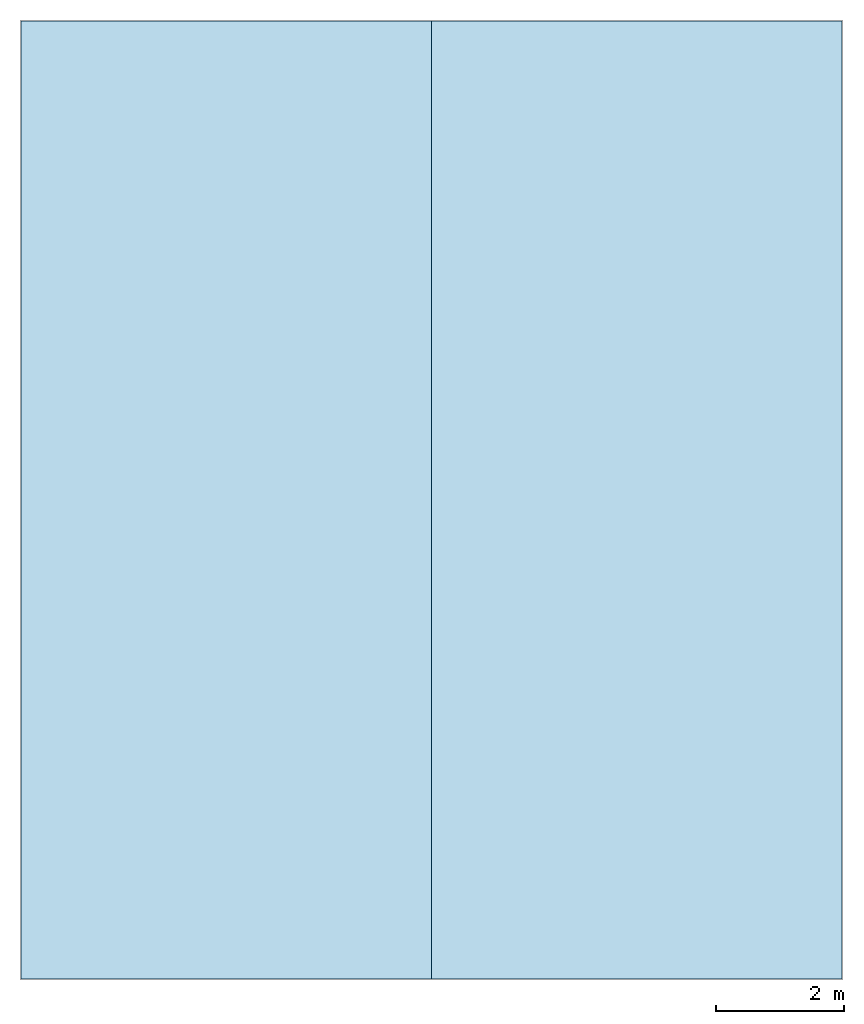
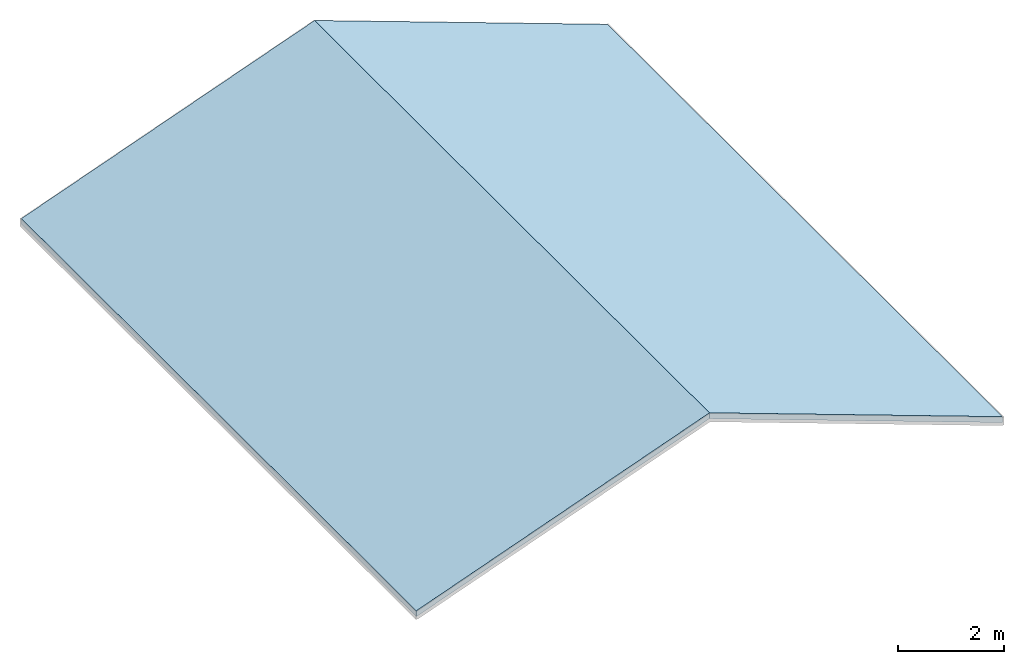
# One storey, part 1 of 2: 2 slabs, 1 element without a shape of its own.
"""IFC2X3 building model written with IfcOpenShell, lengths in feet."""

from ifc_helpers import new_model, entity, si_unit, converted_unit, derived_unit, direction, frame, frame_2d, origin, origin_2d_with_axis, place, context, subcontext, project, spatial, rectangle, extrude, material, layer, layer_set, type_object, element, aggregate, save


model = new_model("IFC2X3")

# Units and contexts
model_context = context("Model", 3, precision=0.0001, world=origin(), true_north=direction((6.123031769111886e-17, 1.0)))
body_context = subcontext(model_context, "Body", "Model", "MODEL_VIEW")
ifc_project = project(units=[converted_unit("LENGTHUNIT", "FOOT", entity("IfcLengthMeasure", 0.3048), si_unit("LENGTHUNIT", "METRE"), dimensions=[1, 0, 0, 0, 0, 0, 0]), converted_unit("AREAUNIT", "SQUARE FOOT", entity("IfcAreaMeasure", 0.09290304), si_unit("AREAUNIT", "SQUARE_METRE"), dimensions=[2, 0, 0, 0, 0, 0, 0]), converted_unit("VOLUMEUNIT", "CUBIC FOOT", entity("IfcVolumeMeasure", 0.028316846592000004), si_unit("VOLUMEUNIT", "CUBIC_METRE"), dimensions=[3, 0, 0, 0, 0, 0, 0]), converted_unit("PLANEANGLEUNIT", "DEGREE", entity("IfcPlaneAngleMeasure", 0.017453292519943278), si_unit("PLANEANGLEUNIT", "RADIAN"), dimensions=[0, 0, 0, 0, 0, 0, 0]), si_unit("MASSUNIT", "GRAM", prefix="KILO"), derived_unit("MASSDENSITYUNIT", [(si_unit("MASSUNIT", "GRAM", prefix="KILO"), 1), (si_unit("LENGTHUNIT", "METRE"), -3)]), derived_unit("IONCONCENTRATIONUNIT", [(si_unit("MASSUNIT", "GRAM", prefix="KILO"), 1), (si_unit("LENGTHUNIT", "METRE"), -3)]), derived_unit("MOMENTOFINERTIAUNIT", [(si_unit("LENGTHUNIT", "METRE"), 4)]), si_unit("TIMEUNIT", "SECOND"), si_unit("FREQUENCYUNIT", "HERTZ"), si_unit("THERMODYNAMICTEMPERATUREUNIT", "DEGREE_CELSIUS"), derived_unit("THERMALTRANSMITTANCEUNIT", [(si_unit("MASSUNIT", "GRAM", prefix="KILO"), 1), (si_unit("THERMODYNAMICTEMPERATUREUNIT", "KELVIN"), -1), (si_unit("TIMEUNIT", "SECOND"), -3)]), derived_unit("THERMALCONDUCTANCEUNIT", [(si_unit("MASSUNIT", "GRAM", prefix="KILO"), 1), (si_unit("THERMODYNAMICTEMPERATUREUNIT", "KELVIN"), -1), (si_unit("TIMEUNIT", "SECOND"), -3), (si_unit("LENGTHUNIT", "METRE"), 1)]), derived_unit("VOLUMETRICFLOWRATEUNIT", [(si_unit("LENGTHUNIT", "METRE"), 3), (si_unit("TIMEUNIT", "SECOND"), -1)]), derived_unit("MASSFLOWRATEUNIT", [(si_unit("MASSUNIT", "GRAM", prefix="KILO"), 1), (si_unit("TIMEUNIT", "SECOND"), -1)]), derived_unit("ROTATIONALFREQUENCYUNIT", [(si_unit("TIMEUNIT", "SECOND"), -1)]), si_unit("ELECTRICCURRENTUNIT", "AMPERE"), si_unit("ELECTRICVOLTAGEUNIT", "VOLT"), si_unit("POWERUNIT", "WATT"), converted_unit("FORCEUNIT", "KIP", entity("IfcForceMeasure", 2.088543423315013e-05), si_unit("FORCEUNIT", "NEWTON"), dimensions=[1, 1, -2, 0, 0, 0, 0]), si_unit("ILLUMINANCEUNIT", "LUX"), si_unit("LUMINOUSFLUXUNIT", "LUMEN"), si_unit("LUMINOUSINTENSITYUNIT", "CANDELA"), si_unit("ENERGYUNIT", "JOULE"), derived_unit("USERDEFINED", [(si_unit("MASSUNIT", "GRAM", prefix="KILO"), -1), (si_unit("LENGTHUNIT", "METRE"), -2), (si_unit("TIMEUNIT", "SECOND"), 3), (si_unit("LUMINOUSFLUXUNIT", "LUMEN"), 1)]), derived_unit("USERDEFINED", [(si_unit("MASSUNIT", "GRAM", prefix="KILO"), 1), (si_unit("TIMEUNIT", "SECOND"), -3), (si_unit("LENGTHUNIT", "METRE"), 3), (si_unit("ELECTRICCURRENTUNIT", "AMPERE"), -2)]), derived_unit("SOUNDPOWERUNIT", [(si_unit("MASSUNIT", "GRAM", prefix="KILO"), 1), (si_unit("TIMEUNIT", "SECOND"), -3), (si_unit("LENGTHUNIT", "METRE"), 2)]), derived_unit("SOUNDPRESSUREUNIT", [(si_unit("MASSUNIT", "GRAM", prefix="KILO"), 1), (si_unit("LENGTHUNIT", "METRE"), -1), (si_unit("TIMEUNIT", "SECOND"), -2)]), derived_unit("LINEARVELOCITYUNIT", [(si_unit("LENGTHUNIT", "METRE"), 1), (si_unit("TIMEUNIT", "SECOND"), -1)]), si_unit("PRESSUREUNIT", "PASCAL"), derived_unit("USERDEFINED", [(si_unit("MASSUNIT", "GRAM", prefix="KILO"), 1), (si_unit("LENGTHUNIT", "METRE"), -2), (si_unit("TIMEUNIT", "SECOND"), -2)]), derived_unit("LINEARFORCEUNIT", [(si_unit("MASSUNIT", "GRAM", prefix="KILO"), 1), (si_unit("TIMEUNIT", "SECOND"), -2)]), derived_unit("PLANARFORCEUNIT", [(si_unit("MASSUNIT", "GRAM", prefix="KILO"), 1), (si_unit("LENGTHUNIT", "METRE"), -1), (si_unit("TIMEUNIT", "SECOND"), -2)]), derived_unit("SPECIFICHEATCAPACITYUNIT", [(si_unit("THERMODYNAMICTEMPERATUREUNIT", "KELVIN"), -1), (si_unit("LENGTHUNIT", "METRE"), 2), (si_unit("TIMEUNIT", "SECOND"), -2)]), derived_unit("HEATFLUXDENSITYUNIT", [(si_unit("MASSUNIT", "GRAM", prefix="KILO"), 1), (si_unit("TIMEUNIT", "SECOND"), -3)]), derived_unit("HEATINGVALUEUNIT", [(si_unit("LENGTHUNIT", "METRE"), 2), (si_unit("TIMEUNIT", "SECOND"), -2)]), derived_unit("VAPORPERMEABILITYUNIT", [(si_unit("LENGTHUNIT", "METRE"), -1), (si_unit("TIMEUNIT", "SECOND"), 1)]), derived_unit("DYNAMICVISCOSITYUNIT", [(si_unit("MASSUNIT", "GRAM", prefix="KILO"), 1), (si_unit("TIMEUNIT", "SECOND"), -1), (si_unit("LENGTHUNIT", "METRE"), -1)]), derived_unit("THERMALEXPANSIONCOEFFICIENTUNIT", [(si_unit("THERMODYNAMICTEMPERATUREUNIT", "KELVIN"), -1)]), derived_unit("MODULUSOFELASTICITYUNIT", [(si_unit("MASSUNIT", "GRAM", prefix="KILO"), 1), (si_unit("LENGTHUNIT", "METRE"), -1), (si_unit("TIMEUNIT", "SECOND"), -2)]), derived_unit("ISOTHERMALMOISTURECAPACITYUNIT", [(si_unit("LENGTHUNIT", "METRE"), 3), (si_unit("MASSUNIT", "GRAM", prefix="KILO"), -1)]), derived_unit("MOISTUREDIFFUSIVITYUNIT", [(si_unit("TIMEUNIT", "SECOND"), -1), (si_unit("LENGTHUNIT", "METRE"), 2)]), derived_unit("MASSPERLENGTHUNIT", [(si_unit("MASSUNIT", "GRAM", prefix="KILO"), 1), (si_unit("LENGTHUNIT", "METRE"), -1)]), derived_unit("THERMALRESISTANCEUNIT", [(si_unit("MASSUNIT", "GRAM", prefix="KILO"), -1), (si_unit("TIMEUNIT", "SECOND"), 3), (si_unit("THERMODYNAMICTEMPERATUREUNIT", "KELVIN"), 1)]), derived_unit("ACCELERATIONUNIT", [(si_unit("LENGTHUNIT", "METRE"), 1), (si_unit("TIMEUNIT", "SECOND"), -2)]), derived_unit("ANGULARVELOCITYUNIT", [(si_unit("TIMEUNIT", "SECOND"), -1), (si_unit("PLANEANGLEUNIT", "RADIAN"), 1)]), derived_unit("LINEARSTIFFNESSUNIT", [(si_unit("MASSUNIT", "GRAM", prefix="KILO"), 1), (si_unit("TIMEUNIT", "SECOND"), -2)]), derived_unit("WARPINGCONSTANTUNIT", [(si_unit("LENGTHUNIT", "METRE"), 6)]), derived_unit("LINEARMOMENTUNIT", [(si_unit("MASSUNIT", "GRAM", prefix="KILO"), 1), (si_unit("LENGTHUNIT", "METRE"), 1), (si_unit("TIMEUNIT", "SECOND"), -2)]), derived_unit("TORQUEUNIT", [(si_unit("MASSUNIT", "GRAM", prefix="KILO"), 1), (si_unit("LENGTHUNIT", "METRE"), 2), (si_unit("TIMEUNIT", "SECOND"), -2)])], contexts=[model_context])

# Site, building, storey
site_placement = place(None, origin())
site = spatial("IfcSite", under=ifc_project, at=site_placement, CompositionType="ELEMENT")
building_placement = place(site_placement, origin())
building = spatial("IfcBuilding", under=site, at=building_placement, CompositionType="ELEMENT")
storey_placement = place(building_placement, frame((0.0, 0.0, 28.25000000000186)))
storey = spatial("IfcBuildingStorey", under=building, at=storey_placement, Name="Third Floor", CompositionType="ELEMENT", Elevation=28.25000000000186)

# Roof, slabs
ifc_material = material(Name="Default Roof")
ifc_layer = layer(ifc_material, 0.4166666666666667)
ifc_layer_set = layer_set([ifc_layer])
roof_placement = place(storey_placement, frame((7.874478019163185, -51.84124484724977, 0.0)))
roof = element("IfcRoof", 1, at=roof_placement, inside=storey, material=ifc_layer_set, ShapeType="NOTDEFINED")
type_product = type_object("IfcTypeProduct")
slab_1_placement = place(roof_placement, origin())
slab_1 = element("IfcSlab", 2, at=slab_1_placement, type_object=type_product, material=ifc_layer_set, PredefinedType="ROOF", context=body_context, shape_type="SweptSolid", body=[
    extrude(rectangle(XDim=49.0000000000002, YDim=22.34773322199428, at=frame_2d((0.0, 0.0), x_axis=(0.0, 1.0))), frame((10.500000000000057, 24.5000000000001, 3.8216874597951502), z_axis=(-0.3420201433256691, 0.0, 0.9396926207859082), x_axis=(0.9396926207859082, 0.0, 0.3420201433256691)), (0.3420201433256691, 0.0, 0.9396926207859082), 0.44340740519829325),
])
slab_2_placement = place(roof_placement, origin())
slab_2 = element("IfcSlab", 3, at=slab_2_placement, type_object=type_product, material=ifc_layer_set, PredefinedType="ROOF", context=body_context, shape_type="SweptSolid", body=[
    extrude(rectangle(XDim=22.3477332219942, YDim=49.0000000000002, at=origin_2d_with_axis()), frame((31.500000000000128, 24.5000000000001, 3.8216874597951502), z_axis=(0.34202014332567027, 0.0, 0.9396926207859079), x_axis=(0.9396926207859079, 0.0, -0.34202014332567027)), (-0.34202014332567027, 0.0, 0.9396926207859079), 0.44340740519829325),
])
aggregate(roof, [slab_1, slab_2])

save(model, "model.ifc")
